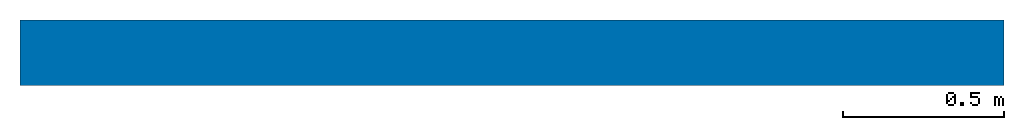
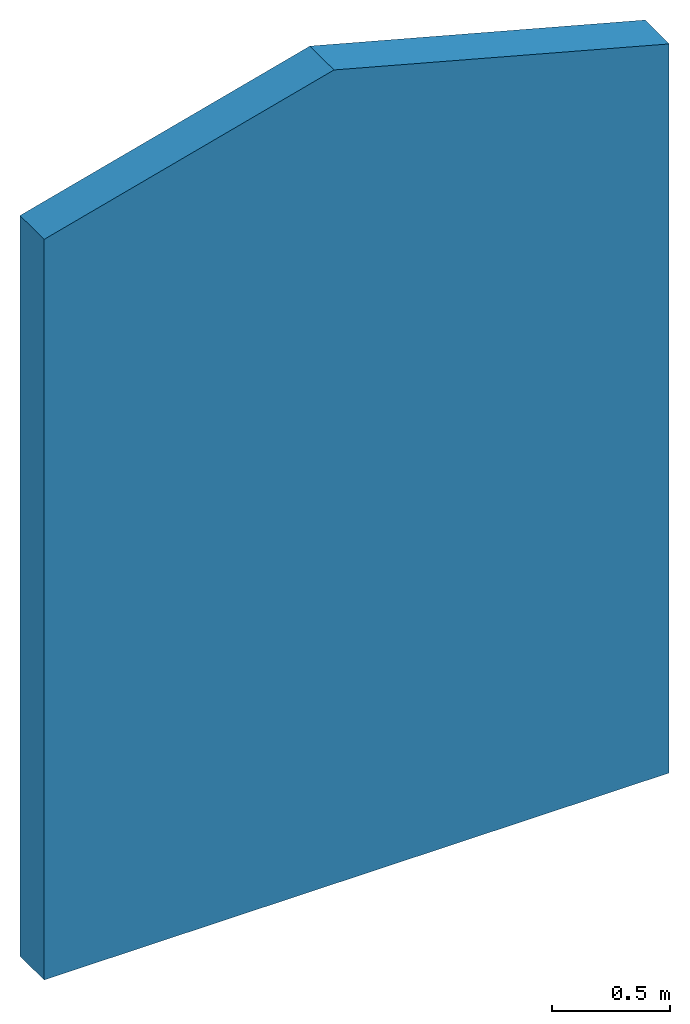
# One storey: 1 wall.
"""IFC4 building model written with IfcOpenShell, lengths in feet."""

from ifc_helpers import new_model, entity, si_unit, converted_unit, derived_unit, direction, frame, frame_2d, origin, place, context, subcontext, project, spatial, polyline, rectangle, extrude, clip, bounded_halfspace, material, layer, layer_set, layer_usage, type_object, element, save


model = new_model("IFC4")

# Units and contexts
model_context = context("Model", 3, precision=0.0001, world=origin(), true_north=direction((6.12303176911189e-17, 1.0)))
body_context = subcontext(model_context, "Body", "Model", "MODEL_VIEW")
ifc_project = project(units=[converted_unit("LENGTHUNIT", "FOOT", entity("IfcRatioMeasure", 0.3048), si_unit("LENGTHUNIT", "METRE"), dimensions=[1, 0, 0, 0, 0, 0, 0]), converted_unit("AREAUNIT", "SQUARE FOOT", entity("IfcRatioMeasure", 0.09290304), si_unit("AREAUNIT", "SQUARE_METRE"), dimensions=[2, 0, 0, 0, 0, 0, 0]), converted_unit("VOLUMEUNIT", "CUBIC FOOT", entity("IfcRatioMeasure", 0.028316846592), si_unit("VOLUMEUNIT", "CUBIC_METRE"), dimensions=[3, 0, 0, 0, 0, 0, 0]), converted_unit("PLANEANGLEUNIT", "DEGREE", entity("IfcRatioMeasure", 0.0174532925199433), si_unit("PLANEANGLEUNIT", "RADIAN"), dimensions=[0, 0, 0, 0, 0, 0, 0]), si_unit("MASSUNIT", "GRAM", prefix="KILO"), derived_unit("MASSDENSITYUNIT", [(si_unit("MASSUNIT", "GRAM", prefix="KILO"), 1), (si_unit("LENGTHUNIT", "METRE"), -3)]), derived_unit("MOMENTOFINERTIAUNIT", [(si_unit("LENGTHUNIT", "METRE"), 4)]), si_unit("TIMEUNIT", "SECOND"), si_unit("FREQUENCYUNIT", "HERTZ"), si_unit("THERMODYNAMICTEMPERATUREUNIT", "DEGREE_CELSIUS"), derived_unit("THERMALTRANSMITTANCEUNIT", [(si_unit("MASSUNIT", "GRAM", prefix="KILO"), 1), (si_unit("THERMODYNAMICTEMPERATUREUNIT", "KELVIN"), -1), (si_unit("TIMEUNIT", "SECOND"), -3)]), derived_unit("VOLUMETRICFLOWRATEUNIT", [(si_unit("LENGTHUNIT", "METRE"), 3), (si_unit("TIMEUNIT", "SECOND"), -1)]), si_unit("ELECTRICCURRENTUNIT", "AMPERE"), si_unit("ELECTRICVOLTAGEUNIT", "VOLT"), si_unit("POWERUNIT", "WATT"), si_unit("FORCEUNIT", "NEWTON"), si_unit("ILLUMINANCEUNIT", "LUX"), si_unit("LUMINOUSFLUXUNIT", "LUMEN"), si_unit("LUMINOUSINTENSITYUNIT", "CANDELA"), derived_unit("USERDEFINED", [(si_unit("MASSUNIT", "GRAM", prefix="KILO"), -1), (si_unit("LENGTHUNIT", "METRE"), -2), (si_unit("TIMEUNIT", "SECOND"), 3), (si_unit("LUMINOUSFLUXUNIT", "LUMEN"), 1)]), derived_unit("LINEARVELOCITYUNIT", [(si_unit("LENGTHUNIT", "METRE"), 1), (si_unit("TIMEUNIT", "SECOND"), -1)]), si_unit("PRESSUREUNIT", "PASCAL"), derived_unit("USERDEFINED", [(si_unit("LENGTHUNIT", "METRE"), -2), (si_unit("MASSUNIT", "GRAM", prefix="KILO"), 1), (si_unit("TIMEUNIT", "SECOND"), -2)]), derived_unit("LINEARFORCEUNIT", [(si_unit("MASSUNIT", "GRAM", prefix="KILO"), 1), (si_unit("LENGTHUNIT", "METRE"), 1), (si_unit("TIMEUNIT", "SECOND"), -2), (si_unit("LENGTHUNIT", "METRE"), -1)]), derived_unit("PLANARFORCEUNIT", [(si_unit("MASSUNIT", "GRAM", prefix="KILO"), 1), (si_unit("LENGTHUNIT", "METRE"), 1), (si_unit("TIMEUNIT", "SECOND"), -2), (si_unit("LENGTHUNIT", "METRE"), -2)])], contexts=[model_context])

# Site, building, storey
site_placement = place(None, origin())
site = spatial("IfcSite", under=ifc_project, at=site_placement, CompositionType="ELEMENT")
building_placement = place(site_placement, origin())
building = spatial("IfcBuilding", under=site, at=building_placement, CompositionType="ELEMENT")
storey_placement = place(building_placement, origin())
storey = spatial("IfcBuildingStorey", under=building, at=storey_placement, Name="Level 1", CompositionType="ELEMENT", Elevation=0.0)

# Wall
ifc_material_1 = material(Name="1", Category="Materials")
ifc_layer_1 = layer(ifc_material_1, 0.333333333333333, Name="1", Category="Materials")
ifc_material_2 = material(Name="2", Category="Materials")
ifc_layer_2 = layer(ifc_material_2, 0.333333333333333, Name="2", Category="Materials")
ifc_layer_set = layer_set([ifc_layer_1, ifc_layer_2])
ifc_layer_usage = layer_usage(ifc_layer_set, "AXIS2", "NEGATIVE", 0.333333333333333)
wall_type = type_object("IfcWallType", PredefinedType="STANDARD", material=ifc_layer_set)
wall_placement = place(storey_placement, origin())
element("IfcWall", 1, at=wall_placement, inside=storey, type_object=wall_type, material=ifc_layer_usage, PredefinedType="NOTDEFINED", context=body_context, shape_type="Clipping", body=[
    clip(clip(extrude(rectangle(XDim=10.0, YDim=0.666666666666667, at=frame_2d((5.0, 0.0), x_axis=(-1.0, 0.0))), origin(), (0.0, 0.0, 1.0), 13.7664035859799), bounded_halfspace(frame((4.63764344876883, -0.333333333333333, 13.7664035859799), z_axis=(0.25881904510252, 0.0, 0.965925826289069), x_axis=(0.0, 1.0, 0.0)), False, frame((4.63764344876883, -0.333333333333333, 13.7664035859799)), polyline([(0.0, 0.0), (5.36235655123117, 0.0), (5.36235655123117, 0.666666666666667), (0.0, 0.666666666666667), (0.0, 0.0)]))), bounded_halfspace(frame((0.0, -0.333333333333333, 12.5237507690988), z_axis=(-0.25881904510252, 0.0, 0.965925826289069), x_axis=(0.0, -1.0, 0.0)), False, frame((0.0, -0.333333333333333, 12.5237507690988)), polyline([(0.0, 0.0), (4.63764344876883, 0.0), (4.63764344876883, 0.666666666666667), (0.0, 0.666666666666667), (0.0, 0.0)]))),
])

save(model, "model.ifc")
